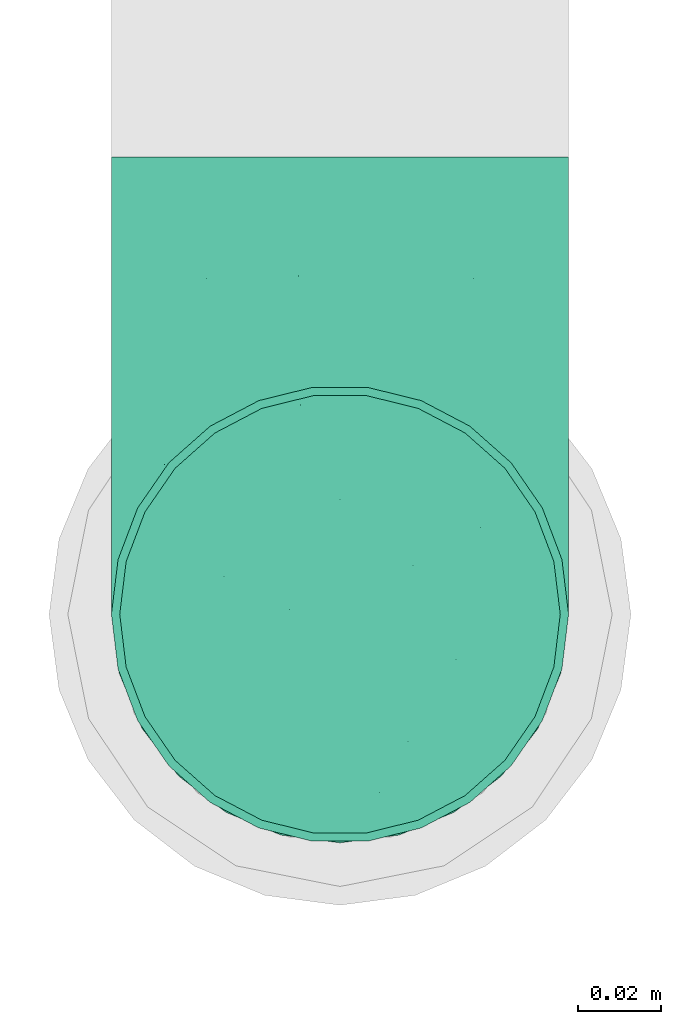
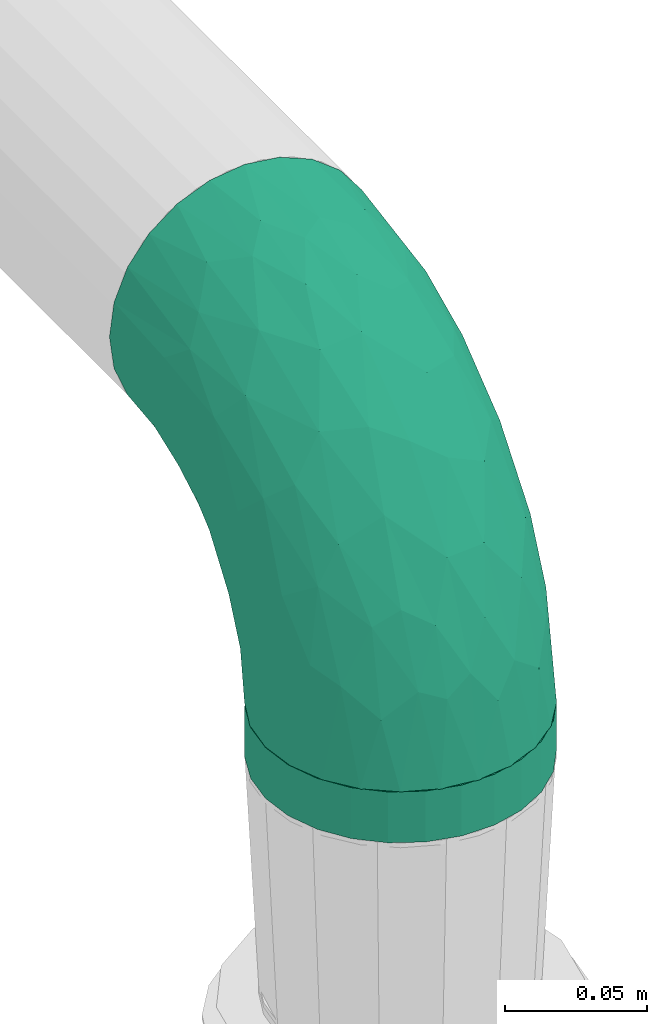
# One storey, part 97 of 123: 1 flow fitting, 1 flow segment.
"""IFC2X3 building model written with IfcOpenShell, lengths in millimetres."""

from ifc_helpers import new_model, entity, si_unit, converted_unit, derived_unit, direction, frame, origin_with_axes, origin_2d_with_axis, place, context, subcontext, project, spatial, hollow_circle, extrude, open_shell, surface_model, source, transform, mapped, material, layer, layer_set, layer_usage, type_object, element, save


model = new_model("IFC2X3")

# Units and contexts
model_context = context("Model", 3, precision=1e-05, world=origin_with_axes(), true_north=direction((0.0, 1.0)))
body_context = subcontext(model_context, "Body", "Model", "MODEL_VIEW")
ifc_project = project(units=[si_unit("AREAUNIT", "SQUARE_METRE"), si_unit("VOLUMEUNIT", "CUBIC_METRE", prefix="DECI"), si_unit("TIMEUNIT", "SECOND"), si_unit("THERMODYNAMICTEMPERATUREUNIT", "DEGREE_CELSIUS"), si_unit("PRESSUREUNIT", "PASCAL"), si_unit("MASSUNIT", "GRAM", prefix="KILO"), si_unit("LENGTHUNIT", "METRE", prefix="MILLI"), si_unit("POWERUNIT", "WATT"), si_unit("ELECTRICCURRENTUNIT", "AMPERE"), si_unit("ELECTRICVOLTAGEUNIT", "VOLT"), derived_unit("VOLUMETRICFLOWRATEUNIT", [(si_unit("VOLUMEUNIT", "CUBIC_METRE", prefix="DECI"), 1), (si_unit("TIMEUNIT", "SECOND"), -1)]), derived_unit("LINEARVELOCITYUNIT", [(si_unit("LENGTHUNIT", "METRE"), 1), (si_unit("TIMEUNIT", "SECOND"), -1)]), derived_unit("MASSDENSITYUNIT", [(si_unit("MASSUNIT", "GRAM", prefix="KILO"), 1), (si_unit("VOLUMEUNIT", "CUBIC_METRE"), -1)]), converted_unit("PLANEANGLEUNIT", "DEGREE", entity("IfcRatioMeasure", 0.01745), si_unit("PLANEANGLEUNIT", "RADIAN"), dimensions=[0, 0, 0, 0, 0, 0, 0])], contexts=[model_context])

# Site, building, storey
site_placement = place(None, origin_with_axes())
site = spatial("IfcSite", under=ifc_project, at=site_placement, CompositionType="ELEMENT")
building_placement = place(site_placement, origin_with_axes())
building = spatial("IfcBuilding", under=site, at=building_placement, Name="mc-building", CompositionType="ELEMENT")
storey_placement = place(building_placement, origin_with_axes())
storey = spatial("IfcBuildingStorey", under=building, at=storey_placement, Name="1. Korrus", CompositionType="ELEMENT", Elevation=0.0)

# Flow segment
ifc_material = material(Name="FZ1")
ifc_layer = layer(ifc_material, 0.0)
ifc_layer_set = layer_set([ifc_layer], Name="FZ1")
ifc_layer_usage = layer_usage(ifc_layer_set, "AXIS1", "POSITIVE", 0.0)
duct_segment_type = type_object("IfcDuctSegmentType", PredefinedType="RIGIDSEGMENT")
shared_shape_1 = source(origin_with_axes(), body_context, "Body", "SweptSolid", [
    extrude(hollow_circle(Radius=55.0, WallThickness=2.0, at=origin_2d_with_axis()), frame((0.0, 0.0, 0.0), z_axis=(1.0, 0.0, 0.0), x_axis=(0.0, 1.0, 0.0)), (0.0, 0.0, 1.0), 21.9),
])
flow_segment_placement = place(storey_placement, frame((29888.82784, 8983.57591, 2325.0), z_axis=(0.0, 1.0, 0.0), x_axis=(0.0, 0.0, -1.0)))
element("IfcFlowSegment", 1, at=flow_segment_placement, inside=storey, type_object=duct_segment_type, material=ifc_layer_usage, context=body_context, shape_type="MappedRepresentation", body=[
    mapped(shared_shape_1, transform((0.0, 0.0, 0.0), scale=1.0)),
])

# Flow fitting
duct_fitting_type = type_object("IfcDuctFittingType", Name="BU", PredefinedType="BEND")
shared_shape_2 = source(origin_with_axes(), body_context, "Body", "SurfaceModel", [
    surface_model("IfcShellBasedSurfaceModel", [(-110.0, 0.0, -55.0), (-110.0, -14.23505, -53.12592), (-110.0, 14.23505, -53.12592), (-110.0, 53.12592, 14.23505), (-110.0, 27.5, -47.63139), (-110.0, 38.89087, -38.89087), (-110.0, -55.0, 0.0), (-110.0, -53.12592, 14.23505), (-110.0, -38.89087, -38.89087), (-110.0, -27.5, -47.63139), (-110.0, -53.12592, -14.23505), (-110.0, -47.63139, -27.5), (-110.0, -14.23505, 53.12592), (-110.0, 14.23505, 53.12592), (-110.0, 27.5, 47.63139), (-110.0, -47.63139, 27.5), (-110.0, -38.89087, 38.89087), (-110.0, -27.5, 47.63139), (-110.0, 0.0, 55.0), (-110.0, 55.0, 0.0), (-110.0, 53.12592, -14.23505), (-110.0, 47.63139, -27.5), (-110.0, 47.63139, 27.5), (-110.0, 38.89087, 38.89087), (-14.23505, 110.0, -53.12592), (-55.0, 110.0, 0.0), (0.0, 110.0, -55.0), (-27.5, 110.0, -47.63139), (-38.89087, 110.0, -38.89087), (-47.63139, 110.0, -27.5), (38.89087, 110.0, -38.89087), (53.12592, 110.0, 14.23505), (27.5, 110.0, -47.63139), (14.23505, 110.0, -53.12592), (47.63139, 110.0, -27.5), (53.12592, 110.0, -14.23505), (55.0, 110.0, 0.0), (-53.12592, 110.0, -14.23505), (-53.12592, 110.0, 14.23505), (-47.63139, 110.0, 27.5), (-38.89087, 110.0, 38.89087), (-27.5, 110.0, 47.63139), (0.0, 110.0, 55.0), (-14.23505, 110.0, 53.12592), (38.89087, 110.0, 38.89087), (47.63139, 110.0, 27.5), (27.5, 110.0, 47.63139), (14.23505, 110.0, 53.12592), (-64.21732, 48.68956, 43.63444), (-76.6405, 38.18013, 45.55988), (-60.44912, 32.56953, 51.94617), (-76.00813, 5.38378, 55.0), (-90.15553, 11.94394, 54.09138), (-78.5998, 26.77405, 50.81338), (-70.18771, 18.55163, 54.03432), (-75.55424, 54.2118, 32.41257), (-93.27622, 45.77614, 33.48188), (-96.12334, 22.13664, 50.81337), (-21.00813, 45.34362, 55.0), (-18.36258, 70.48427, 54.04484), (-32.04182, 59.64019, 52.24446), (-63.88653, 74.77858, 17.99134), (-74.66383, 63.08407, 19.92123), (-63.60674, 66.07878, 29.97482), (-99.597, 52.72185, 18.52927), (-93.11138, 56.59448, 10.50359), (-98.21577, 57.34403, 0.0), (-53.42855, 92.60092, 21.04759), (-88.54852, 54.8376, 21.04759), (-11.86161, 90.23965, 54.10313), (-5.38378, 76.00813, 55.0), (-57.34403, 98.21577, 0.0), (-56.64619, 93.12774, 10.22088), (-45.34362, 21.00813, 55.0), (-44.60838, 44.60838, 52.13415), (-92.68484, 35.46673, 43.63443), (-22.25266, 95.40765, 50.81337), (-35.97783, 90.61597, 43.63443), (-43.70931, 69.58671, 44.47149), (-27.23711, 77.39884, 50.81337), (-57.2828, 79.3123, 24.9774), (-58.67786, 84.31125, 16.04456), (-82.93277, 60.36161, 12.91784), (-49.88337, 54.51816, 47.224), (-74.57753, 66.83759, 9.55742), (-45.35812, 94.97281, 33.48188), (-59.18663, 88.95241, 0.0), (-51.517, 78.6292, 33.48188), (-65.14788, 80.03077, 0.0), (-56.45322, 62.06476, 39.63545), (-88.95241, 59.18663, 0.0), (-71.10913, 71.10913, 0.0), (-80.03077, 65.14788, 0.0), (-94.9309, 45.36788, -33.48188), (-93.11358, 56.60141, -10.46614), (-99.64997, 52.79499, -18.30015), (-90.20425, 36.08686, -43.63443), (-79.99933, 46.56772, -37.92748), (-76.00813, 5.38378, -55.0), (-72.75364, 19.68651, -53.60527), (-45.34362, 21.00813, -55.0), (-21.91957, 65.12078, -53.85897), (-5.38378, 76.00813, -55.0), (-21.00813, 45.34362, -55.0), (-35.41876, 92.89265, -43.63443), (-91.10309, 11.02766, -54.21832), (-45.77614, 93.27622, -33.48188), (-90.50474, 23.21022, -50.81337), (-70.92854, 33.31794, -49.51754), (-78.52933, 63.35627, -11.73997), (-24.91508, 84.05606, -50.81337), (-88.78941, 54.74452, -21.04759), (-69.59921, 57.34866, -33.48187), (-73.36422, 62.46673, -22.94182), (-63.49062, 67.59111, -28.46929), (-56.59448, 93.11138, -10.50359), (-54.8376, 88.54852, -21.04759), (-54.10679, 75.85581, -32.31867), (-57.75956, 31.09612, -52.80882), (-52.72185, 99.597, -18.52927), (-12.62913, 89.46304, -53.99097), (-34.46825, 66.46123, -50.04329), (-43.9837, 43.9837, -52.42279), (-65.78527, 72.58348, -17.68796), (-70.34468, 43.65295, -44.21951), (-57.47001, 51.99467, -44.91465), (-60.72547, 82.29174, -12.88567), (-42.34915, 74.24548, -43.63444), (-57.25194, 63.5016, -38.08211), (-80.95344, 53.56991, -29.32027), (-52.32891, 4.55257, -54.0482), (32.52942, 47.13398, -30.48571), (14.88266, 20.92917, -33.7947), (14.95561, 36.05775, -42.26543), (30.24048, 70.09027, -41.7461), (19.3559, 65.35825, -48.00507), (-70.35075, -46.44478, -19.5952), (-47.13398, -32.52942, -30.48571), (-28.49299, -30.5778, -16.4009), (-4.55257, 52.32891, -54.0482), (-22.4954, 22.4954, -53.25347), (-75.47368, -11.22546, -52.60718), (-81.32209, -51.5606, -9.98467), (-80.81763, -41.84862, -32.14655), (-70.09027, -30.24048, -41.7461), (-36.05774, -14.95561, -42.26543), (-9.15831, -10.852, -27.8997), (-65.35825, -19.3559, -48.00507), (11.22546, 75.47368, -52.60718), (3.94376, 43.9333, -50.53315), (-13.39742, 13.39743, -48.13058), (-43.9333, -3.94376, -50.53315), (49.37776, 67.29486, 0.0), (41.8609, 47.82256, -9.92641), (50.20582, 74.51695, -9.9731), (18.93131, 11.7156, -17.56239), (-27.5, -32.89419, 0.0), (-1.23348, -12.25375, -12.18106), (41.84862, 80.81763, -32.14655), (35.70604, 41.31408, -20.38235), (46.44478, 70.35075, -19.5952), (32.89419, 27.5, 0.0), (6.67262, -6.67262, 0.0), (-67.29486, -49.37776, 0.0), (-50.36265, -42.95545, -9.51562), (-5.47251, 5.47251, -39.92906), (-70.35075, -46.44478, 19.5952), (-74.51695, -50.20582, 9.9731), (-41.31407, -35.70604, 20.38235), (-47.13398, -32.52942, 30.48571), (-80.81763, -41.84862, 32.14655), (-4.55257, 52.32891, 54.0482), (11.22546, 75.47368, 52.60718), (-43.9333, -3.94376, 50.53315), (-65.35825, -19.3559, 48.00507), (-36.05774, -14.95561, 42.26543), (-70.09027, -30.24048, 41.7461), (-11.7156, -18.93131, 17.56239), (30.5778, 28.49299, 16.4009), (12.25375, 1.23348, 12.18106), (51.5606, 81.32209, 9.98467), (42.95545, 50.36265, 9.51562), (-75.47368, -11.22546, 52.60718), (-52.32891, 4.55257, 54.0482), (3.94376, 43.9333, 50.53315), (-22.4954, 22.4954, 53.25347), (-13.39742, 13.39743, 48.13058), (10.852, 9.15831, 27.8997), (-20.92916, -14.88266, 33.79469), (-47.82256, -41.8609, 9.92641), (32.52942, 47.13398, 30.48571), (46.44478, 70.35075, 19.5952), (41.84862, 80.81763, 32.14655), (30.24048, 70.09027, 41.7461), (19.3559, 65.35825, 48.00507), (14.95561, 36.05775, 42.26543), (-5.47251, 5.47251, 39.92906)], [open_shell([[[0, 1, 2]], [[2, 3, 4]], [[4, 3, 5]], [[2, 6, 7]], [[8, 6, 9]], [[1, 9, 6]], [[10, 6, 11]], [[8, 11, 6]], [[6, 2, 1]], [[12, 13, 14]], [[15, 2, 7]], [[16, 17, 2]], [[2, 17, 12]], [[12, 18, 13]], [[19, 20, 3]], [[5, 3, 21]], [[20, 21, 3]], [[22, 3, 2]], [[23, 22, 2]], [[12, 14, 2]], [[2, 14, 23]], [[15, 16, 2]], [[24, 25, 26]], [[27, 25, 24]], [[25, 28, 29]], [[28, 25, 27]], [[30, 26, 31]], [[26, 30, 32]], [[32, 33, 26]], [[34, 31, 35]], [[31, 34, 30]], [[35, 31, 36]], [[29, 37, 25]], [[38, 39, 26]], [[39, 40, 26]], [[41, 42, 40]], [[42, 26, 40]], [[42, 41, 43]], [[26, 44, 45]], [[31, 26, 45]], [[26, 46, 44]], [[47, 46, 26]], [[42, 47, 26]], [[25, 38, 26]], [[48, 49, 50]], [[18, 51, 52]], [[53, 54, 50]], [[55, 56, 49]], [[56, 22, 23]], [[13, 57, 14]], [[58, 59, 60]], [[61, 62, 63]], [[3, 64, 65]], [[53, 52, 54]], [[3, 65, 66]], [[67, 39, 38]], [[56, 68, 64]], [[65, 64, 68]], [[69, 59, 70]], [[38, 71, 72]], [[73, 58, 74]], [[75, 49, 56]], [[76, 69, 43]], [[53, 57, 52]], [[77, 78, 79]], [[41, 76, 43]], [[43, 69, 42]], [[55, 68, 56]], [[23, 14, 75]], [[76, 77, 79]], [[80, 67, 81]], [[62, 82, 68]], [[60, 78, 83]], [[62, 84, 82]], [[85, 77, 40]], [[81, 67, 72]], [[86, 72, 71]], [[87, 85, 67]], [[61, 81, 88]], [[77, 41, 40]], [[78, 77, 87]], [[23, 75, 56]], [[83, 89, 48]], [[85, 40, 39]], [[62, 68, 55]], [[89, 87, 63]], [[83, 48, 50]], [[57, 75, 14]], [[49, 75, 53]], [[67, 85, 39]], [[87, 77, 85]], [[63, 62, 55]], [[89, 55, 48]], [[80, 63, 87]], [[66, 65, 90]], [[66, 19, 3]], [[84, 91, 92]], [[92, 90, 82]], [[65, 82, 90]], [[61, 84, 62]], [[92, 82, 84]], [[68, 82, 65]], [[3, 22, 64]], [[56, 64, 22]], [[38, 25, 71]], [[81, 72, 86]], [[38, 72, 67]], [[91, 61, 88]], [[80, 81, 61]], [[63, 80, 61]], [[67, 80, 87]], [[77, 76, 41]], [[79, 59, 69]], [[79, 69, 76]], [[42, 69, 70]], [[60, 59, 79]], [[58, 70, 59]], [[78, 60, 79]], [[58, 60, 74]], [[52, 57, 13]], [[75, 57, 53]], [[18, 52, 13]], [[52, 51, 54]], [[51, 73, 54]], [[50, 73, 74]], [[73, 50, 54]], [[50, 74, 83]], [[60, 83, 74]], [[89, 83, 78]], [[87, 89, 78]], [[55, 89, 63]], [[50, 49, 53]], [[55, 49, 48]], [[81, 86, 88]], [[91, 84, 61]], [[5, 21, 93]], [[90, 94, 66]], [[20, 94, 95]], [[96, 93, 97]], [[98, 99, 100]], [[96, 4, 5]], [[101, 102, 103]], [[28, 27, 104]], [[2, 105, 0]], [[104, 106, 28]], [[99, 105, 107]], [[108, 107, 96]], [[90, 109, 94]], [[107, 2, 4]], [[20, 66, 94]], [[27, 24, 110]], [[109, 111, 94]], [[112, 113, 114]], [[37, 115, 71]], [[116, 106, 117]], [[99, 118, 100]], [[116, 115, 119]], [[37, 119, 115]], [[24, 120, 110]], [[121, 110, 101]], [[119, 106, 116]], [[101, 110, 120]], [[122, 103, 100]], [[117, 123, 116]], [[124, 125, 108]], [[115, 116, 126]], [[106, 29, 28]], [[26, 102, 120]], [[127, 104, 110]], [[97, 124, 96]], [[125, 122, 118]], [[128, 127, 125]], [[96, 5, 93]], [[115, 126, 86]], [[117, 106, 127]], [[111, 113, 129]], [[95, 93, 21]], [[97, 129, 112]], [[110, 104, 27]], [[106, 104, 127]], [[96, 107, 4]], [[99, 107, 108]], [[99, 108, 118]], [[105, 99, 98]], [[112, 114, 128]], [[121, 125, 127]], [[20, 19, 66]], [[109, 90, 92]], [[94, 111, 95]], [[91, 123, 109]], [[129, 113, 112]], [[93, 95, 111]], [[21, 20, 95]], [[71, 115, 86]], [[71, 25, 37]], [[123, 91, 88]], [[126, 116, 123]], [[123, 88, 126]], [[86, 126, 88]], [[37, 29, 119]], [[106, 119, 29]], [[129, 93, 111]], [[124, 112, 125]], [[0, 105, 98]], [[107, 105, 2]], [[125, 118, 108]], [[100, 118, 122]], [[93, 129, 97]], [[113, 111, 109]], [[109, 123, 113]], [[114, 123, 117]], [[123, 114, 113]], [[128, 114, 117]], [[127, 128, 117]], [[112, 128, 125]], [[103, 122, 101]], [[110, 121, 127]], [[101, 122, 121]], [[125, 121, 122]], [[26, 120, 24]], [[101, 120, 102]], [[96, 124, 108]], [[92, 91, 109]], [[112, 124, 97]], [[100, 130, 98]], [[131, 132, 133]], [[32, 134, 135]], [[136, 137, 138]], [[139, 140, 103]], [[98, 141, 0]], [[142, 10, 136]], [[143, 144, 137]], [[6, 10, 142]], [[137, 145, 146]], [[144, 147, 145]], [[143, 136, 11]], [[11, 136, 10]], [[8, 143, 11]], [[148, 149, 139]], [[8, 9, 144]], [[9, 1, 147]], [[130, 141, 98]], [[103, 140, 100]], [[148, 135, 149]], [[150, 151, 140]], [[152, 153, 154]], [[130, 140, 151]], [[148, 26, 33]], [[147, 1, 141]], [[155, 146, 132]], [[156, 138, 157]], [[134, 30, 158]], [[150, 140, 149]], [[158, 30, 34]], [[30, 134, 32]], [[153, 159, 160]], [[131, 160, 159]], [[144, 145, 137]], [[36, 152, 154]], [[146, 138, 137]], [[155, 161, 162]], [[158, 160, 131]], [[133, 149, 135]], [[156, 163, 164]], [[163, 142, 164]], [[139, 103, 102]], [[153, 152, 161]], [[34, 35, 160]], [[162, 157, 155]], [[132, 165, 133]], [[157, 146, 155]], [[140, 130, 100]], [[141, 130, 151]], [[141, 151, 147]], [[141, 1, 0]], [[102, 26, 148]], [[140, 139, 149]], [[102, 148, 139]], [[135, 33, 32]], [[151, 150, 145]], [[9, 147, 144]], [[151, 145, 147]], [[145, 165, 146]], [[135, 148, 33]], [[133, 135, 134]], [[131, 133, 134]], [[133, 165, 150]], [[133, 150, 149]], [[145, 150, 165]], [[132, 131, 159]], [[146, 165, 132]], [[160, 158, 34]], [[134, 158, 131]], [[144, 143, 8]], [[136, 143, 137]], [[155, 153, 161]], [[154, 153, 160]], [[153, 155, 159]], [[132, 159, 155]], [[160, 35, 154]], [[36, 154, 35]], [[164, 136, 138]], [[6, 142, 163]], [[136, 164, 142]], [[156, 164, 138]], [[156, 157, 162]], [[146, 157, 138]], [[15, 7, 166]], [[6, 163, 167]], [[168, 169, 166]], [[166, 169, 170]], [[171, 172, 70]], [[173, 174, 175]], [[17, 176, 174]], [[177, 156, 162]], [[176, 16, 170]], [[170, 16, 15]], [[161, 178, 179]], [[152, 180, 181]], [[182, 173, 183]], [[18, 12, 182]], [[184, 185, 186]], [[183, 185, 73]], [[183, 73, 51]], [[177, 187, 188]], [[189, 168, 166]], [[187, 178, 190]], [[16, 176, 17]], [[161, 152, 181]], [[45, 191, 31]], [[45, 44, 192]], [[192, 191, 45]], [[180, 36, 31]], [[193, 194, 195]], [[46, 47, 194]], [[193, 195, 190]], [[193, 44, 46]], [[172, 42, 70]], [[185, 58, 73]], [[189, 163, 156]], [[163, 189, 167]], [[70, 58, 171]], [[184, 171, 185]], [[169, 188, 175]], [[180, 31, 191]], [[192, 193, 190]], [[191, 190, 178]], [[182, 174, 173]], [[194, 47, 172]], [[190, 195, 187]], [[186, 185, 173]], [[162, 179, 177]], [[188, 196, 175]], [[179, 187, 177]], [[185, 171, 58]], [[172, 171, 184]], [[172, 184, 194]], [[172, 47, 42]], [[51, 18, 182]], [[185, 183, 173]], [[51, 182, 183]], [[174, 12, 17]], [[184, 186, 195]], [[46, 194, 193]], [[184, 195, 194]], [[195, 196, 187]], [[174, 182, 12]], [[175, 174, 176]], [[169, 175, 176]], [[175, 196, 186]], [[175, 186, 173]], [[195, 186, 196]], [[188, 169, 168]], [[187, 196, 188]], [[166, 170, 15]], [[176, 170, 169]], [[193, 192, 44]], [[191, 192, 190]], [[177, 189, 156]], [[167, 189, 166]], [[189, 177, 168]], [[188, 168, 177]], [[166, 7, 167]], [[6, 167, 7]], [[181, 191, 178]], [[36, 180, 152]], [[191, 181, 180]], [[161, 181, 178]], [[161, 179, 162]], [[187, 179, 178]]])]),
])
flow_fitting_placement = place(storey_placement, frame((29888.82784, 8983.57591, 2435.0), z_axis=(1.0, 0.0, 0.0), x_axis=(0.0, -1.0, 0.0)))
element("IfcFlowFitting", 2, at=flow_fitting_placement, inside=storey, type_object=duct_fitting_type, Name="BU", context=body_context, shape_type="MappedRepresentation", body=[
    mapped(shared_shape_2, transform((0.0, 0.0, 0.0), scale=1.0)),
])

save(model, "model.ifc")
